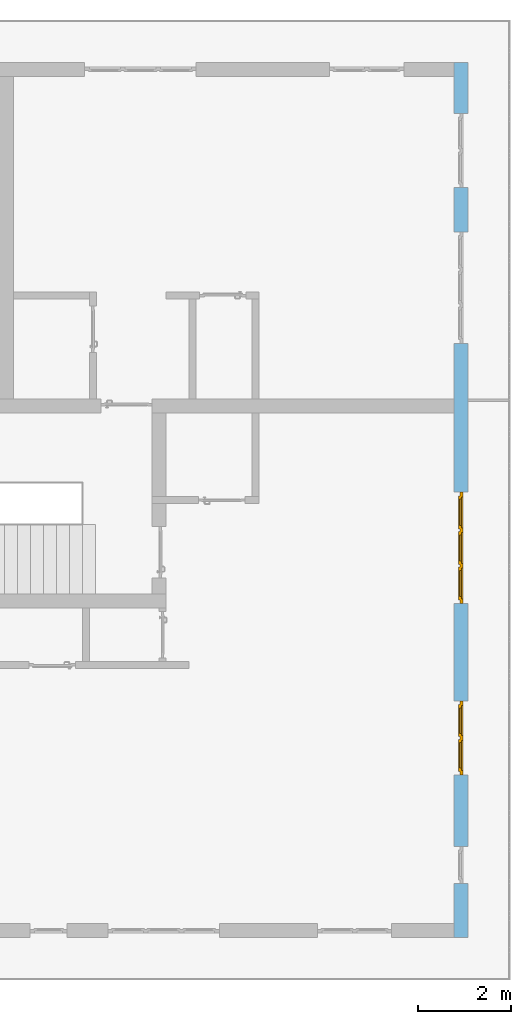
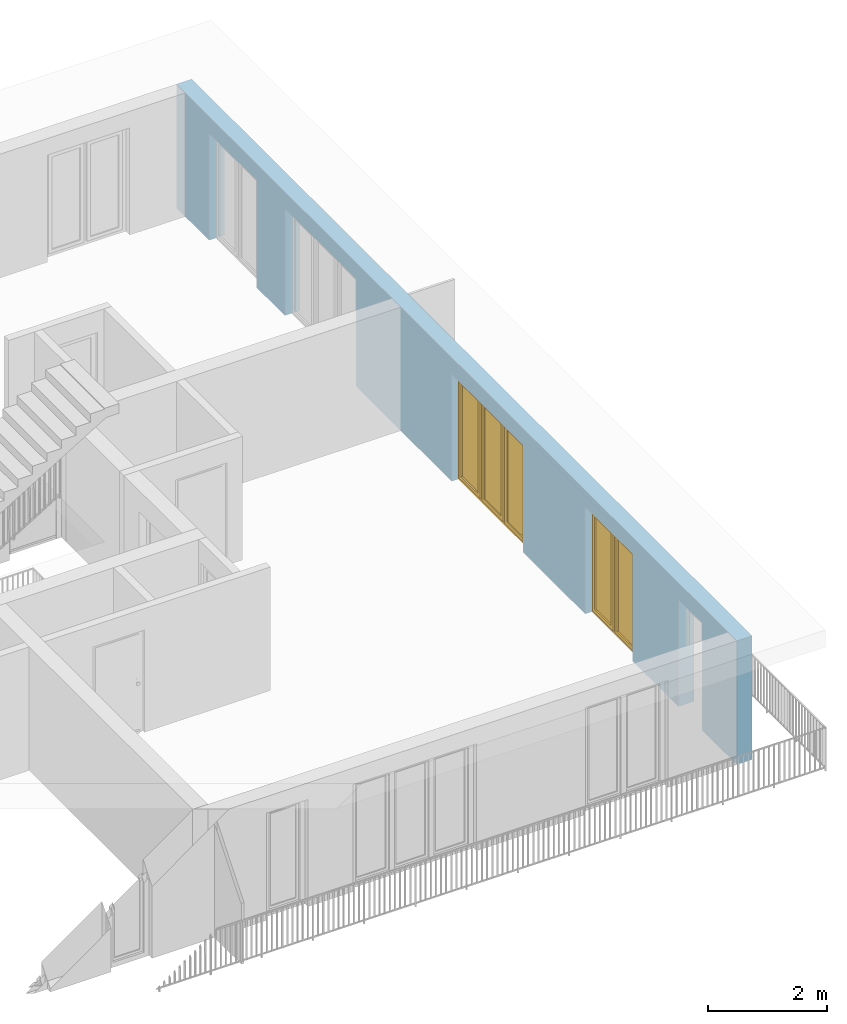
# One storey, part 18 of 48: 2 windows, 5 openings, plus 1 element that does not belong to this part.
"""IFC4 building model written with IfcOpenShell, lengths in metres."""

from ifc_helpers import new_model, entity, si_unit, converted_unit, derived_unit, direction, frame, origin_with_axes, place, context, subcontext, project, spatial, polygons, source, transform, mapped, material, type_object, element, fill, save


model = new_model("IFC4")

# Units and contexts
model_context = context("Model", 3, precision=1e-05, world=origin_with_axes(), true_north=direction((0.0, 1.0)))
body_context = subcontext(model_context, "Body", "Model", "MODEL_VIEW")
ifc_project = project(units=[si_unit("LENGTHUNIT", "METRE"), si_unit("AREAUNIT", "SQUARE_METRE"), si_unit("VOLUMEUNIT", "CUBIC_METRE"), converted_unit("PLANEANGLEUNIT", "DEGREE", entity("IfcPlaneAngleMeasure", 0.0174532925199), si_unit("PLANEANGLEUNIT", "RADIAN"), dimensions=[0, 0, 0, 0, 0, 0, 0]), converted_unit("TIMEUNIT", "Year", entity("IfcTimeMeasure", 31556926.0), si_unit("TIMEUNIT", "SECOND"), dimensions=[0, 0, 1, 0, 0, 0, 0]), si_unit("MASSUNIT", "GRAM", prefix="KILO"), si_unit("THERMODYNAMICTEMPERATUREUNIT", "DEGREE_CELSIUS"), si_unit("LUMINOUSINTENSITYUNIT", "LUMEN"), si_unit("ENERGYUNIT", "JOULE", prefix="MEGA"), derived_unit("THERMALCONDUCTANCEUNIT", [(si_unit("POWERUNIT", "WATT"), 1), (si_unit("LENGTHUNIT", "METRE"), -1), (si_unit("THERMODYNAMICTEMPERATUREUNIT", "KELVIN"), -1)]), derived_unit("SPECIFICHEATCAPACITYUNIT", [(si_unit("ENERGYUNIT", "JOULE"), 1), (si_unit("MASSUNIT", "GRAM", prefix="KILO"), -1), (si_unit("THERMODYNAMICTEMPERATUREUNIT", "KELVIN"), -1)]), derived_unit("MASSDENSITYUNIT", [(si_unit("MASSUNIT", "GRAM", prefix="KILO"), 1), (si_unit("VOLUMEUNIT", "CUBIC_METRE"), -1)])], contexts=[model_context])

# Site, building, storey
site_placement = place(None, origin_with_axes())
site = spatial("IfcSite", under=ifc_project, at=site_placement, CompositionType="ELEMENT")
building_placement = place(site_placement, origin_with_axes())
building = spatial("IfcBuilding", under=site, at=building_placement, CompositionType="ELEMENT")
storey_placement = place(building_placement, frame((0.0, 0.0, 3.4), z_axis=(0.0, 0.0, 1.0), x_axis=(1.0, 0.0, 0.0)))
storey = spatial("IfcBuildingStorey", under=building, at=storey_placement, Name="1. Geschoss", CompositionType="ELEMENT", Elevation=3.4)

# Wall, openings, windows
ifc_material = material()
wall_type = type_object("IfcWallType", Name="300", PredefinedType="NOTDEFINED")
wall_placement = place(storey_placement, frame((9.3378006196, -9.92881223104, 0.0), z_axis=(0.0, 0.0, 1.0), x_axis=(0.0, 1.0, 0.0)))
wall = element("IfcWall", 1, at=wall_placement, inside=storey, type_object=wall_type, material=ifc_material, Name="Wand-001", PredefinedType="NOTDEFINED", context=body_context, shape_type="Tessellation", body=[
    polygons([(1.16441876325, 0.1, 2.2), (1.96441876325, 0.1, 2.2), (1.96441876325, 0.0, 2.2), (1.16441876325, 0.0, 2.2), (1.16441876325, 0.3, 2.2), (1.96441876325, 0.3, 2.2), (1.96441876325, 0.1, 0.0), (1.96441876325, 0.0, 0.0), (18.85, 0.0, 2.54), (0.0, 0.0, 2.54), (0.0, 0.0, 0.0), (1.16441876325, 0.0, 0.0), (3.5, 0.0, 0.0), (3.5, 0.0, 2.2), (5.1, 0.0, 2.2), (5.1, 0.0, 0.0), (7.1921181063, 0.0, 0.0), (7.1921181063, 0.0, 2.2), (9.5921181063, 0.0, 2.2), (9.5921181063, 0.0, 0.0), (12.8, 0.0, 0.0), (12.8, 0.0, 2.2), (15.2, 0.0, 2.2), (15.2, 0.0, 0.0), (16.15, 0.0, 0.0), (16.15, 0.0, 2.2), (17.75, 0.0, 2.2), (17.75, 0.0, 0.0), (18.85, 0.0, 0.0), (1.16441876325, 0.1, 0.0), (1.16441876325, 0.3, 0.0), (0.0, 0.3, 0.0), (0.0, 0.3, 2.54), (18.85, 0.3, 2.54), (18.85, 0.3, 0.0), (17.75, 0.3, 0.0), (17.75, 0.3, 2.2), (16.15, 0.3, 2.2), (16.15, 0.3, 0.0), (15.2, 0.3, 0.0), (15.2, 0.3, 2.2), (12.8, 0.3, 2.2), (12.8, 0.3, 0.0), (9.5921181063, 0.3, 0.0), (9.5921181063, 0.3, 2.2), (7.1921181063, 0.3, 2.2), (7.1921181063, 0.3, 0.0), (5.1, 0.3, 0.0), (5.1, 0.3, 2.2), (3.5, 0.3, 2.2), (3.5, 0.3, 0.0), (1.96441876325, 0.3, 0.0), (3.5, 0.1, 0.0), (3.5, 0.1, 2.2), (5.1, 0.1, 2.2), (5.1, 0.1, 0.0), (7.1921181063, 0.1, 0.0), (7.1921181063, 0.1, 2.2), (9.5921181063, 0.1, 2.2), (9.5921181063, 0.1, 0.0), (12.8, 0.1, 0.0), (12.8, 0.1, 2.2), (15.2, 0.1, 2.2), (15.2, 0.1, 0.0), (16.15, 0.1, 0.0), (16.15, 0.1, 2.2), (17.75, 0.1, 2.2), (17.75, 0.1, 0.0)], [[[1, 2, 3, 4]], [[2, 1, 5, 6]], [[2, 7, 8, 3]], [[9, 10, 11, 12, 4, 3, 8, 13, 14, 15, 16, 17, 18, 19, 20, 21, 22, 23, 24, 25, 26, 27, 28, 29]], [[30, 1, 4, 12]], [[1, 30, 31, 5]], [[5, 31, 32, 33, 34, 35, 36, 37, 38, 39, 40, 41, 42, 43, 44, 45, 46, 47, 48, 49, 50, 51, 52, 6]], [[7, 2, 6, 52]], [[7, 52, 51, 53, 13, 8]], [[9, 34, 33, 10]], [[33, 32, 11, 10]], [[31, 30, 12, 11, 32]], [[14, 13, 53, 54]], [[15, 14, 54, 55]], [[16, 15, 55, 56]], [[56, 48, 47, 57, 17, 16]], [[57, 58, 18, 17]], [[58, 59, 19, 18]], [[59, 60, 20, 19]], [[60, 44, 43, 61, 21, 20]], [[22, 21, 61, 62]], [[23, 22, 62, 63]], [[24, 23, 63, 64]], [[64, 40, 39, 65, 25, 24]], [[65, 66, 26, 25]], [[66, 67, 27, 26]], [[67, 68, 28, 27]], [[36, 35, 29, 28, 68]], [[9, 29, 35, 34]], [[68, 67, 37, 36]], [[67, 66, 38, 37]], [[66, 65, 39, 38]], [[41, 40, 64, 63]], [[42, 41, 63, 62]], [[43, 42, 62, 61]], [[60, 59, 45, 44]], [[59, 58, 46, 45]], [[58, 57, 47, 46]], [[49, 48, 56, 55]], [[50, 49, 55, 54]], [[51, 50, 54, 53]]], closed=True),
])
opening_1_placement = place(wall_placement, frame((16.95, 0.0, 0.0), z_axis=(0.0, 0.0, 1.0), x_axis=(1.0, 0.0, 0.0)))
element("IfcOpeningElement", 2, at=opening_1_placement, cuts=wall, Name="Fenster-001", context=body_context, identifier="Reference", shape_type="Tessellation", body=[
    polygons([(0.8, 0.1, 0.0), (0.8, 0.1, 2.2), (0.8, -0.000999999999999, 2.2), (0.8, -0.000999999999999, 0.0), (0.8, 0.301, 0.0), (0.8, 0.301, 2.2), (-0.8, 0.1, 2.2), (-0.8, -0.000999999999999, 2.2), (-0.8, 0.301, 2.2), (-0.8, -0.000999999999999, 0.0), (-0.8, 0.1, 0.0), (-0.8, 0.301, 0.0)], [[[1, 2, 3, 4]], [[2, 1, 5, 6]], [[7, 8, 3, 2, 6, 9]], [[8, 10, 4, 3]], [[1, 4, 10, 11, 12, 5]], [[6, 5, 12, 9]], [[7, 11, 10, 8]], [[11, 7, 9, 12]]], closed=True),
])
opening_2_placement = place(wall_placement, frame((14.0, 0.0, 0.0), z_axis=(0.0, 0.0, 1.0), x_axis=(1.0, 0.0, 0.0)))
element("IfcOpeningElement", 3, at=opening_2_placement, cuts=wall, Name="Fenster-002", context=body_context, identifier="Reference", shape_type="Tessellation", body=[
    polygons([(1.2, 0.1, 0.0), (1.2, 0.1, 2.2), (1.2, -0.000999999999999, 2.2), (1.2, -0.000999999999999, 0.0), (1.2, 0.301, 0.0), (1.2, 0.301, 2.2), (-1.2, 0.1, 2.2), (-1.2, -0.000999999999999, 2.2), (-1.2, 0.301, 2.2), (-1.2, -0.000999999999999, 0.0), (-1.2, 0.1, 0.0), (-1.2, 0.301, 0.0)], [[[1, 2, 3, 4]], [[2, 1, 5, 6]], [[7, 8, 3, 2, 6, 9]], [[8, 10, 4, 3]], [[1, 4, 10, 11, 12, 5]], [[6, 5, 12, 9]], [[7, 11, 10, 8]], [[11, 7, 9, 12]]], closed=True),
])
opening_3_placement = place(wall_placement, frame((8.3921181063, 0.0, 0.0), z_axis=(0.0, 0.0, 1.0), x_axis=(1.0, 0.0, 0.0)))
opening_3 = element("IfcOpeningElement", 4, at=opening_3_placement, cuts=wall, Name="Fenster-002", context=body_context, identifier="Reference", shape_type="Tessellation", body=[
    polygons([(1.2, 0.1, 0.0), (1.2, 0.1, 2.2), (1.2, -0.000999999999999, 2.2), (1.2, -0.000999999999999, 0.0), (1.2, 0.301, 0.0), (1.2, 0.301, 2.2), (-1.2, 0.1, 2.2), (-1.2, -0.000999999999999, 2.2), (-1.2, 0.301, 2.2), (-1.2, -0.000999999999999, 0.0), (-1.2, 0.1, 0.0), (-1.2, 0.301, 0.0)], [[[1, 2, 3, 4]], [[2, 1, 5, 6]], [[7, 8, 3, 2, 6, 9]], [[8, 10, 4, 3]], [[1, 4, 10, 11, 12, 5]], [[6, 5, 12, 9]], [[7, 11, 10, 8]], [[11, 7, 9, 12]]], closed=True),
])
opening_4_placement = place(wall_placement, frame((4.3, 0.0, 0.0), z_axis=(0.0, 0.0, 1.0), x_axis=(1.0, 0.0, 0.0)))
opening_4 = element("IfcOpeningElement", 5, at=opening_4_placement, cuts=wall, Name="Fenster-001", context=body_context, identifier="Reference", shape_type="Tessellation", body=[
    polygons([(0.8, 0.1, 0.0), (0.8, 0.1, 2.2), (0.8, -0.000999999999999, 2.2), (0.8, -0.000999999999999, 0.0), (0.8, 0.301, 0.0), (0.8, 0.301, 2.2), (-0.8, 0.1, 2.2), (-0.8, -0.000999999999999, 2.2), (-0.8, 0.301, 2.2), (-0.8, -0.000999999999999, 0.0), (-0.8, 0.1, 0.0), (-0.8, 0.301, 0.0)], [[[1, 2, 3, 4]], [[2, 1, 5, 6]], [[7, 8, 3, 2, 6, 9]], [[8, 10, 4, 3]], [[1, 4, 10, 11, 12, 5]], [[6, 5, 12, 9]], [[7, 11, 10, 8]], [[11, 7, 9, 12]]], closed=True),
])
opening_5_placement = place(wall_placement, frame((1.56441876325, 0.0, 0.0), z_axis=(0.0, 0.0, 1.0), x_axis=(1.0, 0.0, 0.0)))
element("IfcOpeningElement", 6, at=opening_5_placement, cuts=wall, Name="Fenster-003", context=body_context, identifier="Reference", shape_type="Tessellation", body=[
    polygons([(0.4, 0.1, 0.0), (0.4, 0.1, 2.2), (0.4, -0.000999999999999, 2.2), (0.4, -0.000999999999999, 0.0), (0.4, 0.301, 0.0), (0.4, 0.301, 2.2), (-0.4, 0.1, 2.2), (-0.4, -0.000999999999999, 2.2), (-0.4, 0.301, 2.2), (-0.4, -0.000999999999999, 0.0), (-0.4, 0.1, 0.0), (-0.4, 0.301, 0.0)], [[[1, 2, 3, 4]], [[2, 1, 5, 6]], [[7, 8, 3, 2, 6, 9]], [[8, 10, 4, 3]], [[1, 4, 10, 11, 12, 5]], [[6, 5, 12, 9]], [[7, 11, 10, 8]], [[11, 7, 9, 12]]], closed=True),
])
window_type_1 = type_object("IfcWindowType", Name="3-1+1+1 26", PartitioningType="TRIPLE_PANEL_VERTICAL", PredefinedType="WINDOW")
shared_shape_1 = source(origin_with_axes(), body_context, "Body", "Tessellation", [
    polygons([(-1.2, -0.07, 0.0), (-1.2, 0.0, 0.0), (-1.1, 0.0, 0.1), (-1.1, -0.07, 0.1), (-1.2, -0.07, 2.2), (-1.2, 0.0, 2.2), (-1.1, 0.0, 2.1), (-1.1, -0.07, 2.1)], [[[1, 2, 3, 4]], [[5, 6, 2, 1]], [[2, 6, 7, 3]], [[4, 3, 7, 8]], [[1, 4, 8, 5]], [[8, 7, 6, 5]]], closed=True),
    polygons([(1.2, -0.07, 0.0), (1.2, 0.0, 0.0), (1.2, 0.0, 2.2), (1.2, -0.07, 2.2), (1.1, -0.07, 0.1), (1.1, 0.0, 0.1), (1.1, 0.0, 2.1), (1.1, -0.07, 2.1)], [[[1, 2, 3, 4]], [[5, 6, 2, 1]], [[2, 6, 7, 3]], [[4, 3, 7, 8]], [[1, 4, 8, 5]], [[8, 7, 6, 5]]], closed=True),
    polygons([(-1.2, -0.07, 0.0), (-1.2, 0.0, 0.0), (1.2, 0.0, 0.0), (1.2, -0.07, 0.0), (-1.1, -0.07, 0.1), (-1.1, 0.0, 0.1), (-0.433333333333, 0.0, 0.1), (-0.333333333333, 0.0, 0.1), (0.333333333333, 0.0, 0.1), (0.433333333333, 0.0, 0.1), (1.1, 0.0, 0.1), (1.1, -0.07, 0.1), (0.433333333333, -0.07, 0.1), (0.333333333333, -0.07, 0.1), (-0.333333333333, -0.07, 0.1), (-0.433333333333, -0.07, 0.1)], [[[1, 2, 3, 4]], [[5, 6, 2, 1]], [[2, 6, 7, 8, 9, 10, 11, 3]], [[4, 3, 11, 12]], [[1, 4, 12, 13, 14, 15, 16, 5]], [[16, 7, 6, 5]], [[15, 8, 7, 16]], [[14, 9, 8, 15]], [[13, 10, 9, 14]], [[12, 11, 10, 13]]], closed=True),
    polygons([(-1.2, -0.07, 2.2), (-1.2, 0.0, 2.2), (-1.1, 0.0, 2.1), (-1.1, -0.07, 2.1), (1.2, -0.07, 2.2), (1.2, 0.0, 2.2), (1.1, 0.0, 2.1), (0.433333333333, 0.0, 2.1), (0.333333333333, 0.0, 2.1), (-0.333333333333, 0.0, 2.1), (-0.433333333333, 0.0, 2.1), (-0.433333333333, -0.07, 2.1), (-0.333333333333, -0.07, 2.1), (0.333333333333, -0.07, 2.1), (0.433333333333, -0.07, 2.1), (1.1, -0.07, 2.1)], [[[1, 2, 3, 4]], [[5, 6, 2, 1]], [[2, 6, 7, 8, 9, 10, 11, 3]], [[4, 3, 11, 12]], [[1, 4, 12, 13, 14, 15, 16, 5]], [[16, 7, 6, 5]], [[15, 8, 7, 16]], [[14, 9, 8, 15]], [[13, 10, 9, 14]], [[12, 11, 10, 13]]], closed=True),
    polygons([(0.333333333333, -0.07, 0.1), (0.333333333333, 0.0, 0.1), (0.433333333333, 0.0, 0.1), (0.433333333333, -0.07, 0.1), (0.333333333333, -0.07, 2.1), (0.333333333333, 0.0, 2.1), (0.433333333333, 0.0, 2.1), (0.433333333333, -0.07, 2.1)], [[[1, 2, 3, 4]], [[5, 6, 2, 1]], [[2, 6, 7, 3]], [[4, 3, 7, 8]], [[1, 4, 8, 5]], [[8, 7, 6, 5]]], closed=True),
    polygons([(-0.433333333333, -0.07, 0.1), (-0.433333333333, 0.0, 0.1), (-0.333333333333, 0.0, 0.1), (-0.333333333333, -0.07, 0.1), (-0.433333333333, -0.07, 2.1), (-0.433333333333, 0.0, 2.1), (-0.333333333333, 0.0, 2.1), (-0.333333333333, -0.07, 2.1)], [[[1, 2, 3, 4]], [[5, 6, 2, 1]], [[2, 6, 7, 3]], [[4, 3, 7, 8]], [[1, 4, 8, 5]], [[8, 7, 6, 5]]], closed=True),
    polygons([(-1.12, 0.0, 0.08), (-1.12, 0.03, 0.08), (-1.05, 0.03, 0.15), (-1.05, 0.0, 0.15), (-1.12, 0.0, 2.12), (-1.12, 0.03, 2.12), (-1.05, 0.03, 2.05), (-1.05, 0.0, 2.05)], [[[1, 2, 3, 4]], [[5, 6, 2, 1]], [[2, 6, 7, 3]], [[4, 3, 7, 8]], [[1, 4, 8, 5]], [[8, 7, 6, 5]]], closed=True),
    polygons([(-0.413333333333, 0.0, 0.08), (-0.483333333333, 0.0, 0.15), (-0.483333333333, 0.03, 0.15), (-0.413333333333, 0.03, 0.08), (-0.413333333333, 0.0, 2.12), (-0.483333333333, 0.0, 2.05), (-0.483333333333, 0.03, 2.05), (-0.413333333333, 0.03, 2.12)], [[[1, 2, 3, 4]], [[1, 5, 6, 2]], [[2, 6, 7, 3]], [[4, 3, 7, 8]], [[5, 1, 4, 8]], [[6, 5, 8, 7]]], closed=True),
    polygons([(-1.12, 0.0, 0.08), (-1.12, 0.03, 0.08), (-0.413333333333, 0.03, 0.08), (-0.413333333333, 0.0, 0.08), (-1.05, 0.0, 0.15), (-1.05, 0.03, 0.15), (-0.483333333333, 0.03, 0.15), (-0.483333333333, 0.0, 0.15)], [[[1, 2, 3, 4]], [[5, 6, 2, 1]], [[2, 6, 7, 3]], [[4, 3, 7, 8]], [[1, 4, 8, 5]], [[8, 7, 6, 5]]], closed=True),
    polygons([(-1.12, 0.0, 2.12), (-0.413333333333, 0.0, 2.12), (-0.413333333333, 0.03, 2.12), (-1.12, 0.03, 2.12), (-1.05, 0.0, 2.05), (-0.483333333333, 0.0, 2.05), (-0.483333333333, 0.03, 2.05), (-1.05, 0.03, 2.05)], [[[1, 2, 3, 4]], [[1, 5, 6, 2]], [[2, 6, 7, 3]], [[4, 3, 7, 8]], [[5, 1, 4, 8]], [[6, 5, 8, 7]]], closed=True),
    polygons([(-1.1, -0.03, 0.1), (-1.1, 0.0, 0.1), (-1.05, 0.0, 0.15), (-1.05, -0.03, 0.15), (-1.1, -0.03, 2.1), (-1.1, 0.0, 2.1), (-1.05, 0.0, 2.05), (-1.05, -0.03, 2.05)], [[[1, 2, 3, 4]], [[5, 6, 2, 1]], [[2, 6, 7, 3]], [[4, 3, 7, 8]], [[1, 4, 8, 5]], [[8, 7, 6, 5]]], closed=True),
    polygons([(-0.433333333333, -0.03, 0.1), (-0.483333333333, -0.03, 0.15), (-0.483333333333, 0.0, 0.15), (-0.433333333333, 0.0, 0.1), (-0.433333333333, -0.03, 2.1), (-0.483333333333, -0.03, 2.05), (-0.483333333333, 0.0, 2.05), (-0.433333333333, 0.0, 2.1)], [[[1, 2, 3, 4]], [[1, 5, 6, 2]], [[2, 6, 7, 3]], [[4, 3, 7, 8]], [[5, 1, 4, 8]], [[6, 5, 8, 7]]], closed=True),
    polygons([(-1.1, -0.03, 0.1), (-1.1, 0.0, 0.1), (-0.433333333333, 0.0, 0.1), (-0.433333333333, -0.03, 0.1), (-1.05, -0.03, 0.15), (-1.05, 0.0, 0.15), (-0.483333333333, 0.0, 0.15), (-0.483333333333, -0.03, 0.15)], [[[1, 2, 3, 4]], [[5, 6, 2, 1]], [[2, 6, 7, 3]], [[4, 3, 7, 8]], [[1, 4, 8, 5]], [[8, 7, 6, 5]]], closed=True),
    polygons([(-1.1, -0.03, 2.1), (-0.433333333333, -0.03, 2.1), (-0.433333333333, 0.0, 2.1), (-1.1, 0.0, 2.1), (-1.05, -0.03, 2.05), (-0.483333333333, -0.03, 2.05), (-0.483333333333, 0.0, 2.05), (-1.05, 0.0, 2.05)], [[[1, 2, 3, 4]], [[1, 5, 6, 2]], [[2, 6, 7, 3]], [[4, 3, 7, 8]], [[5, 1, 4, 8]], [[6, 5, 8, 7]]], closed=True),
    polygons([(-1.05, -0.005, 0.15), (-1.05, 0.005, 0.15), (-0.483333333333, 0.005, 0.15), (-0.483333333333, -0.005, 0.15), (-1.05, -0.005, 2.05), (-1.05, 0.005, 2.05), (-0.483333333333, 0.005, 2.05), (-0.483333333333, -0.005, 2.05)], [[[1, 2, 3, 4]], [[5, 6, 2, 1]], [[2, 6, 7, 3]], [[4, 3, 7, 8]], [[1, 4, 8, 5]], [[8, 7, 6, 5]]], closed=True),
    polygons([(-0.353333333333, 0.0, 0.08), (-0.353333333333, 0.03, 0.08), (-0.283333333333, 0.03, 0.15), (-0.283333333333, 0.0, 0.15), (-0.353333333333, 0.0, 2.12), (-0.353333333333, 0.03, 2.12), (-0.283333333333, 0.03, 2.05), (-0.283333333333, 0.0, 2.05)], [[[1, 2, 3, 4]], [[5, 6, 2, 1]], [[2, 6, 7, 3]], [[4, 3, 7, 8]], [[1, 4, 8, 5]], [[8, 7, 6, 5]]], closed=True),
    polygons([(0.353333333333, 0.0, 0.08), (0.283333333333, 0.0, 0.15), (0.283333333333, 0.03, 0.15), (0.353333333333, 0.03, 0.08), (0.353333333333, 0.0, 2.12), (0.283333333333, 0.0, 2.05), (0.283333333333, 0.03, 2.05), (0.353333333333, 0.03, 2.12)], [[[1, 2, 3, 4]], [[1, 5, 6, 2]], [[2, 6, 7, 3]], [[4, 3, 7, 8]], [[5, 1, 4, 8]], [[6, 5, 8, 7]]], closed=True),
    polygons([(-0.353333333333, 0.0, 0.08), (-0.353333333333, 0.03, 0.08), (0.353333333333, 0.03, 0.08), (0.353333333333, 0.0, 0.08), (-0.283333333333, 0.0, 0.15), (-0.283333333333, 0.03, 0.15), (0.283333333333, 0.03, 0.15), (0.283333333333, 0.0, 0.15)], [[[1, 2, 3, 4]], [[5, 6, 2, 1]], [[2, 6, 7, 3]], [[4, 3, 7, 8]], [[1, 4, 8, 5]], [[8, 7, 6, 5]]], closed=True),
    polygons([(-0.353333333333, 0.0, 2.12), (0.353333333333, 0.0, 2.12), (0.353333333333, 0.03, 2.12), (-0.353333333333, 0.03, 2.12), (-0.283333333333, 0.0, 2.05), (0.283333333333, 0.0, 2.05), (0.283333333333, 0.03, 2.05), (-0.283333333333, 0.03, 2.05)], [[[1, 2, 3, 4]], [[1, 5, 6, 2]], [[2, 6, 7, 3]], [[4, 3, 7, 8]], [[5, 1, 4, 8]], [[6, 5, 8, 7]]], closed=True),
    polygons([(-0.333333333333, -0.03, 0.1), (-0.333333333333, 0.0, 0.1), (-0.283333333333, 0.0, 0.15), (-0.283333333333, -0.03, 0.15), (-0.333333333333, -0.03, 2.1), (-0.333333333333, 0.0, 2.1), (-0.283333333333, 0.0, 2.05), (-0.283333333333, -0.03, 2.05)], [[[1, 2, 3, 4]], [[5, 6, 2, 1]], [[2, 6, 7, 3]], [[4, 3, 7, 8]], [[1, 4, 8, 5]], [[8, 7, 6, 5]]], closed=True),
    polygons([(0.333333333333, -0.03, 0.1), (0.283333333333, -0.03, 0.15), (0.283333333333, 0.0, 0.15), (0.333333333333, 0.0, 0.1), (0.333333333333, -0.03, 2.1), (0.283333333333, -0.03, 2.05), (0.283333333333, 0.0, 2.05), (0.333333333333, 0.0, 2.1)], [[[1, 2, 3, 4]], [[1, 5, 6, 2]], [[2, 6, 7, 3]], [[4, 3, 7, 8]], [[5, 1, 4, 8]], [[6, 5, 8, 7]]], closed=True),
    polygons([(-0.333333333333, -0.03, 0.1), (-0.333333333333, 0.0, 0.1), (0.333333333333, 0.0, 0.1), (0.333333333333, -0.03, 0.1), (-0.283333333333, -0.03, 0.15), (-0.283333333333, 0.0, 0.15), (0.283333333333, 0.0, 0.15), (0.283333333333, -0.03, 0.15)], [[[1, 2, 3, 4]], [[5, 6, 2, 1]], [[2, 6, 7, 3]], [[4, 3, 7, 8]], [[1, 4, 8, 5]], [[8, 7, 6, 5]]], closed=True),
    polygons([(-0.333333333333, -0.03, 2.1), (0.333333333333, -0.03, 2.1), (0.333333333333, 0.0, 2.1), (-0.333333333333, 0.0, 2.1), (-0.283333333333, -0.03, 2.05), (0.283333333333, -0.03, 2.05), (0.283333333333, 0.0, 2.05), (-0.283333333333, 0.0, 2.05)], [[[1, 2, 3, 4]], [[1, 5, 6, 2]], [[2, 6, 7, 3]], [[4, 3, 7, 8]], [[5, 1, 4, 8]], [[6, 5, 8, 7]]], closed=True),
    polygons([(-0.283333333333, -0.005, 0.15), (-0.283333333333, 0.005, 0.15), (0.283333333333, 0.005, 0.15), (0.283333333333, -0.005, 0.15), (-0.283333333333, -0.005, 2.05), (-0.283333333333, 0.005, 2.05), (0.283333333333, 0.005, 2.05), (0.283333333333, -0.005, 2.05)], [[[1, 2, 3, 4]], [[5, 6, 2, 1]], [[2, 6, 7, 3]], [[4, 3, 7, 8]], [[1, 4, 8, 5]], [[8, 7, 6, 5]]], closed=True),
    polygons([(0.413333333333, 0.0, 0.08), (0.413333333333, 0.03, 0.08), (0.483333333333, 0.03, 0.15), (0.483333333333, 0.0, 0.15), (0.413333333333, 0.0, 2.12), (0.413333333333, 0.03, 2.12), (0.483333333333, 0.03, 2.05), (0.483333333333, 0.0, 2.05)], [[[1, 2, 3, 4]], [[5, 6, 2, 1]], [[2, 6, 7, 3]], [[4, 3, 7, 8]], [[1, 4, 8, 5]], [[8, 7, 6, 5]]], closed=True),
    polygons([(1.12, 0.0, 0.08), (1.05, 0.0, 0.15), (1.05, 0.03, 0.15), (1.12, 0.03, 0.08), (1.12, 0.0, 2.12), (1.05, 0.0, 2.05), (1.05, 0.03, 2.05), (1.12, 0.03, 2.12)], [[[1, 2, 3, 4]], [[1, 5, 6, 2]], [[2, 6, 7, 3]], [[4, 3, 7, 8]], [[5, 1, 4, 8]], [[6, 5, 8, 7]]], closed=True),
    polygons([(0.413333333333, 0.0, 0.08), (0.413333333333, 0.03, 0.08), (1.12, 0.03, 0.08), (1.12, 0.0, 0.08), (0.483333333333, 0.0, 0.15), (0.483333333333, 0.03, 0.15), (1.05, 0.03, 0.15), (1.05, 0.0, 0.15)], [[[1, 2, 3, 4]], [[5, 6, 2, 1]], [[2, 6, 7, 3]], [[4, 3, 7, 8]], [[1, 4, 8, 5]], [[8, 7, 6, 5]]], closed=True),
    polygons([(0.413333333333, 0.0, 2.12), (1.12, 0.0, 2.12), (1.12, 0.03, 2.12), (0.413333333333, 0.03, 2.12), (0.483333333333, 0.0, 2.05), (1.05, 0.0, 2.05), (1.05, 0.03, 2.05), (0.483333333333, 0.03, 2.05)], [[[1, 2, 3, 4]], [[1, 5, 6, 2]], [[2, 6, 7, 3]], [[4, 3, 7, 8]], [[5, 1, 4, 8]], [[6, 5, 8, 7]]], closed=True),
    polygons([(0.433333333333, -0.03, 0.1), (0.433333333333, 0.0, 0.1), (0.483333333333, 0.0, 0.15), (0.483333333333, -0.03, 0.15), (0.433333333333, -0.03, 2.1), (0.433333333333, 0.0, 2.1), (0.483333333333, 0.0, 2.05), (0.483333333333, -0.03, 2.05)], [[[1, 2, 3, 4]], [[5, 6, 2, 1]], [[2, 6, 7, 3]], [[4, 3, 7, 8]], [[1, 4, 8, 5]], [[8, 7, 6, 5]]], closed=True),
    polygons([(1.1, -0.03, 0.1), (1.05, -0.03, 0.15), (1.05, 0.0, 0.15), (1.1, 0.0, 0.1), (1.1, -0.03, 2.1), (1.05, -0.03, 2.05), (1.05, 0.0, 2.05), (1.1, 0.0, 2.1)], [[[1, 2, 3, 4]], [[1, 5, 6, 2]], [[2, 6, 7, 3]], [[4, 3, 7, 8]], [[5, 1, 4, 8]], [[6, 5, 8, 7]]], closed=True),
    polygons([(0.433333333333, -0.03, 0.1), (0.433333333333, 0.0, 0.1), (1.1, 0.0, 0.1), (1.1, -0.03, 0.1), (0.483333333333, -0.03, 0.15), (0.483333333333, 0.0, 0.15), (1.05, 0.0, 0.15), (1.05, -0.03, 0.15)], [[[1, 2, 3, 4]], [[5, 6, 2, 1]], [[2, 6, 7, 3]], [[4, 3, 7, 8]], [[1, 4, 8, 5]], [[8, 7, 6, 5]]], closed=True),
    polygons([(0.433333333333, -0.03, 2.1), (1.1, -0.03, 2.1), (1.1, 0.0, 2.1), (0.433333333333, 0.0, 2.1), (0.483333333333, -0.03, 2.05), (1.05, -0.03, 2.05), (1.05, 0.0, 2.05), (0.483333333333, 0.0, 2.05)], [[[1, 2, 3, 4]], [[1, 5, 6, 2]], [[2, 6, 7, 3]], [[4, 3, 7, 8]], [[5, 1, 4, 8]], [[6, 5, 8, 7]]], closed=True),
    polygons([(0.483333333333, -0.005, 0.15), (0.483333333333, 0.005, 0.15), (1.05, 0.005, 0.15), (1.05, -0.005, 0.15), (0.483333333333, -0.005, 2.05), (0.483333333333, 0.005, 2.05), (1.05, 0.005, 2.05), (1.05, -0.005, 2.05)], [[[1, 2, 3, 4]], [[5, 6, 2, 1]], [[2, 6, 7, 3]], [[4, 3, 7, 8]], [[1, 4, 8, 5]], [[8, 7, 6, 5]]], closed=True),
])
window_1_placement = place(opening_3_placement, frame((-1.2, 0.0, 0.0), z_axis=(0.0, 0.0, 1.0), x_axis=(1.0, 0.0, 0.0)))
window_1 = element("IfcWindow", 7, at=window_1_placement, inside=storey, type_object=window_type_1, Name="Fenster-002", OverallHeight=2.2, OverallWidth=2.4, PredefinedType="WINDOW", context=body_context, shape_type="MappedRepresentation", body=[
    mapped(shared_shape_1, transform((1.2, 0.17, 0.0))),
])
fill(opening_3, window_1)
window_type_2 = type_object("IfcWindowType", Name="2-1+1 26", PartitioningType="DOUBLE_PANEL_VERTICAL", PredefinedType="WINDOW")
shared_shape_2 = source(origin_with_axes(), body_context, "Body", "Tessellation", [
    polygons([(0.8, -0.07, 0.0), (0.7, -0.07, 0.1), (0.7, 0.0, 0.1), (0.8, 0.0, 0.0), (0.8, -0.07, 2.2), (0.7, -0.07, 2.1), (0.7, 0.0, 2.1), (0.8, 0.0, 2.2)], [[[1, 2, 3, 4]], [[1, 5, 6, 2]], [[2, 6, 7, 3]], [[4, 3, 7, 8]], [[5, 1, 4, 8]], [[6, 5, 8, 7]]], closed=True),
    polygons([(-0.8, -0.07, 0.0), (-0.8, -0.07, 2.2), (-0.8, 0.0, 2.2), (-0.8, 0.0, 0.0), (-0.7, -0.07, 0.1), (-0.7, -0.07, 2.1), (-0.7, 0.0, 2.1), (-0.7, 0.0, 0.1)], [[[1, 2, 3, 4]], [[1, 5, 6, 2]], [[2, 6, 7, 3]], [[4, 3, 7, 8]], [[5, 1, 4, 8]], [[6, 5, 8, 7]]], closed=True),
    polygons([(0.8, -0.07, 0.0), (-0.8, -0.07, 0.0), (-0.8, 0.0, 0.0), (0.8, 0.0, 0.0), (0.7, -0.07, 0.1), (0.05, -0.07, 0.1), (-0.05, -0.07, 0.1), (-0.7, -0.07, 0.1), (-0.7, 0.0, 0.1), (-0.05, 0.0, 0.1), (0.05, 0.0, 0.1), (0.7, 0.0, 0.1)], [[[1, 2, 3, 4]], [[1, 5, 6, 7, 8, 2]], [[2, 8, 9, 3]], [[4, 3, 9, 10, 11, 12]], [[5, 1, 4, 12]], [[6, 5, 12, 11]], [[7, 6, 11, 10]], [[8, 7, 10, 9]]], closed=True),
    polygons([(0.8, -0.07, 2.2), (0.7, -0.07, 2.1), (0.7, 0.0, 2.1), (0.8, 0.0, 2.2), (-0.8, -0.07, 2.2), (-0.7, -0.07, 2.1), (-0.05, -0.07, 2.1), (0.05, -0.07, 2.1), (0.05, 0.0, 2.1), (-0.05, 0.0, 2.1), (-0.7, 0.0, 2.1), (-0.8, 0.0, 2.2)], [[[1, 2, 3, 4]], [[1, 5, 6, 7, 8, 2]], [[2, 8, 9, 3]], [[4, 3, 9, 10, 11, 12]], [[5, 1, 4, 12]], [[6, 5, 12, 11]], [[7, 6, 11, 10]], [[8, 7, 10, 9]]], closed=True),
    polygons([(0.05, -0.07, 0.1), (-0.05, -0.07, 0.1), (-0.05, 0.0, 0.1), (0.05, 0.0, 0.1), (0.05, -0.07, 2.1), (-0.05, -0.07, 2.1), (-0.05, 0.0, 2.1), (0.05, 0.0, 2.1)], [[[1, 2, 3, 4]], [[1, 5, 6, 2]], [[2, 6, 7, 3]], [[4, 3, 7, 8]], [[5, 1, 4, 8]], [[6, 5, 8, 7]]], closed=True),
    polygons([(0.72, 0.0, 0.08), (0.65, 0.0, 0.15), (0.65, 0.03, 0.15), (0.72, 0.03, 0.08), (0.72, 0.0, 2.12), (0.65, 0.0, 2.05), (0.65, 0.03, 2.05), (0.72, 0.03, 2.12)], [[[1, 2, 3, 4]], [[1, 5, 6, 2]], [[2, 6, 7, 3]], [[4, 3, 7, 8]], [[5, 1, 4, 8]], [[6, 5, 8, 7]]], closed=True),
    polygons([(0.03, 0.0, 0.08), (0.03, 0.03, 0.08), (0.1, 0.03, 0.15), (0.1, 0.0, 0.15), (0.03, 0.0, 2.12), (0.03, 0.03, 2.12), (0.1, 0.03, 2.05), (0.1, 0.0, 2.05)], [[[1, 2, 3, 4]], [[5, 6, 2, 1]], [[2, 6, 7, 3]], [[4, 3, 7, 8]], [[1, 4, 8, 5]], [[8, 7, 6, 5]]], closed=True),
    polygons([(0.72, 0.0, 0.08), (0.03, 0.0, 0.08), (0.03, 0.03, 0.08), (0.72, 0.03, 0.08), (0.65, 0.0, 0.15), (0.1, 0.0, 0.15), (0.1, 0.03, 0.15), (0.65, 0.03, 0.15)], [[[1, 2, 3, 4]], [[1, 5, 6, 2]], [[2, 6, 7, 3]], [[4, 3, 7, 8]], [[5, 1, 4, 8]], [[6, 5, 8, 7]]], closed=True),
    polygons([(0.72, 0.0, 2.12), (0.72, 0.03, 2.12), (0.03, 0.03, 2.12), (0.03, 0.0, 2.12), (0.65, 0.0, 2.05), (0.65, 0.03, 2.05), (0.1, 0.03, 2.05), (0.1, 0.0, 2.05)], [[[1, 2, 3, 4]], [[5, 6, 2, 1]], [[2, 6, 7, 3]], [[4, 3, 7, 8]], [[1, 4, 8, 5]], [[8, 7, 6, 5]]], closed=True),
    polygons([(0.7, -0.03, 0.1), (0.65, -0.03, 0.15), (0.65, 0.0, 0.15), (0.7, 0.0, 0.1), (0.7, -0.03, 2.1), (0.65, -0.03, 2.05), (0.65, 0.0, 2.05), (0.7, 0.0, 2.1)], [[[1, 2, 3, 4]], [[1, 5, 6, 2]], [[2, 6, 7, 3]], [[4, 3, 7, 8]], [[5, 1, 4, 8]], [[6, 5, 8, 7]]], closed=True),
    polygons([(0.05, -0.03, 0.1), (0.05, 0.0, 0.1), (0.1, 0.0, 0.15), (0.1, -0.03, 0.15), (0.05, -0.03, 2.1), (0.05, 0.0, 2.1), (0.1, 0.0, 2.05), (0.1, -0.03, 2.05)], [[[1, 2, 3, 4]], [[5, 6, 2, 1]], [[2, 6, 7, 3]], [[4, 3, 7, 8]], [[1, 4, 8, 5]], [[8, 7, 6, 5]]], closed=True),
    polygons([(0.7, -0.03, 0.1), (0.05, -0.03, 0.1), (0.05, 0.0, 0.1), (0.7, 0.0, 0.1), (0.65, -0.03, 0.15), (0.1, -0.03, 0.15), (0.1, 0.0, 0.15), (0.65, 0.0, 0.15)], [[[1, 2, 3, 4]], [[1, 5, 6, 2]], [[2, 6, 7, 3]], [[4, 3, 7, 8]], [[5, 1, 4, 8]], [[6, 5, 8, 7]]], closed=True),
    polygons([(0.7, -0.03, 2.1), (0.7, 0.0, 2.1), (0.05, 0.0, 2.1), (0.05, -0.03, 2.1), (0.65, -0.03, 2.05), (0.65, 0.0, 2.05), (0.1, 0.0, 2.05), (0.1, -0.03, 2.05)], [[[1, 2, 3, 4]], [[5, 6, 2, 1]], [[2, 6, 7, 3]], [[4, 3, 7, 8]], [[1, 4, 8, 5]], [[8, 7, 6, 5]]], closed=True),
    polygons([(0.65, -0.005, 0.15), (0.1, -0.005, 0.15), (0.1, 0.005, 0.15), (0.65, 0.005, 0.15), (0.65, -0.005, 2.05), (0.1, -0.005, 2.05), (0.1, 0.005, 2.05), (0.65, 0.005, 2.05)], [[[1, 2, 3, 4]], [[1, 5, 6, 2]], [[2, 6, 7, 3]], [[4, 3, 7, 8]], [[5, 1, 4, 8]], [[6, 5, 8, 7]]], closed=True),
    polygons([(-0.03, 0.0, 0.08), (-0.1, 0.0, 0.15), (-0.1, 0.03, 0.15), (-0.03, 0.03, 0.08), (-0.03, 0.0, 2.12), (-0.1, 0.0, 2.05), (-0.1, 0.03, 2.05), (-0.03, 0.03, 2.12)], [[[1, 2, 3, 4]], [[1, 5, 6, 2]], [[2, 6, 7, 3]], [[4, 3, 7, 8]], [[5, 1, 4, 8]], [[6, 5, 8, 7]]], closed=True),
    polygons([(-0.72, 0.0, 0.08), (-0.72, 0.03, 0.08), (-0.65, 0.03, 0.15), (-0.65, 0.0, 0.15), (-0.72, 0.0, 2.12), (-0.72, 0.03, 2.12), (-0.65, 0.03, 2.05), (-0.65, 0.0, 2.05)], [[[1, 2, 3, 4]], [[5, 6, 2, 1]], [[2, 6, 7, 3]], [[4, 3, 7, 8]], [[1, 4, 8, 5]], [[8, 7, 6, 5]]], closed=True),
    polygons([(-0.03, 0.0, 0.08), (-0.72, 0.0, 0.08), (-0.72, 0.03, 0.08), (-0.03, 0.03, 0.08), (-0.1, 0.0, 0.15), (-0.65, 0.0, 0.15), (-0.65, 0.03, 0.15), (-0.1, 0.03, 0.15)], [[[1, 2, 3, 4]], [[1, 5, 6, 2]], [[2, 6, 7, 3]], [[4, 3, 7, 8]], [[5, 1, 4, 8]], [[6, 5, 8, 7]]], closed=True),
    polygons([(-0.03, 0.0, 2.12), (-0.03, 0.03, 2.12), (-0.72, 0.03, 2.12), (-0.72, 0.0, 2.12), (-0.1, 0.0, 2.05), (-0.1, 0.03, 2.05), (-0.65, 0.03, 2.05), (-0.65, 0.0, 2.05)], [[[1, 2, 3, 4]], [[5, 6, 2, 1]], [[2, 6, 7, 3]], [[4, 3, 7, 8]], [[1, 4, 8, 5]], [[8, 7, 6, 5]]], closed=True),
    polygons([(-0.05, -0.03, 0.1), (-0.1, -0.03, 0.15), (-0.1, 0.0, 0.15), (-0.05, 0.0, 0.1), (-0.05, -0.03, 2.1), (-0.1, -0.03, 2.05), (-0.1, 0.0, 2.05), (-0.05, 0.0, 2.1)], [[[1, 2, 3, 4]], [[1, 5, 6, 2]], [[2, 6, 7, 3]], [[4, 3, 7, 8]], [[5, 1, 4, 8]], [[6, 5, 8, 7]]], closed=True),
    polygons([(-0.7, -0.03, 0.1), (-0.7, 0.0, 0.1), (-0.65, 0.0, 0.15), (-0.65, -0.03, 0.15), (-0.7, -0.03, 2.1), (-0.7, 0.0, 2.1), (-0.65, 0.0, 2.05), (-0.65, -0.03, 2.05)], [[[1, 2, 3, 4]], [[5, 6, 2, 1]], [[2, 6, 7, 3]], [[4, 3, 7, 8]], [[1, 4, 8, 5]], [[8, 7, 6, 5]]], closed=True),
    polygons([(-0.05, -0.03, 0.1), (-0.7, -0.03, 0.1), (-0.7, 0.0, 0.1), (-0.05, 0.0, 0.1), (-0.1, -0.03, 0.15), (-0.65, -0.03, 0.15), (-0.65, 0.0, 0.15), (-0.1, 0.0, 0.15)], [[[1, 2, 3, 4]], [[1, 5, 6, 2]], [[2, 6, 7, 3]], [[4, 3, 7, 8]], [[5, 1, 4, 8]], [[6, 5, 8, 7]]], closed=True),
    polygons([(-0.05, -0.03, 2.1), (-0.05, 0.0, 2.1), (-0.7, 0.0, 2.1), (-0.7, -0.03, 2.1), (-0.1, -0.03, 2.05), (-0.1, 0.0, 2.05), (-0.65, 0.0, 2.05), (-0.65, -0.03, 2.05)], [[[1, 2, 3, 4]], [[5, 6, 2, 1]], [[2, 6, 7, 3]], [[4, 3, 7, 8]], [[1, 4, 8, 5]], [[8, 7, 6, 5]]], closed=True),
    polygons([(-0.1, -0.005, 0.15), (-0.65, -0.005, 0.15), (-0.65, 0.005, 0.15), (-0.1, 0.005, 0.15), (-0.1, -0.005, 2.05), (-0.65, -0.005, 2.05), (-0.65, 0.005, 2.05), (-0.1, 0.005, 2.05)], [[[1, 2, 3, 4]], [[1, 5, 6, 2]], [[2, 6, 7, 3]], [[4, 3, 7, 8]], [[5, 1, 4, 8]], [[6, 5, 8, 7]]], closed=True),
])
window_2_placement = place(opening_4_placement, frame((-0.8, 0.0, 0.0), z_axis=(0.0, 0.0, 1.0), x_axis=(1.0, 0.0, 0.0)))
window_2 = element("IfcWindow", 8, at=window_2_placement, inside=storey, type_object=window_type_2, Name="Fenster-001", OverallHeight=2.2, OverallWidth=1.6, PredefinedType="WINDOW", context=body_context, shape_type="MappedRepresentation", body=[
    mapped(shared_shape_2, transform((0.8, 0.17, 0.0))),
])
fill(opening_4, window_2)

save(model, "model.ifc")
